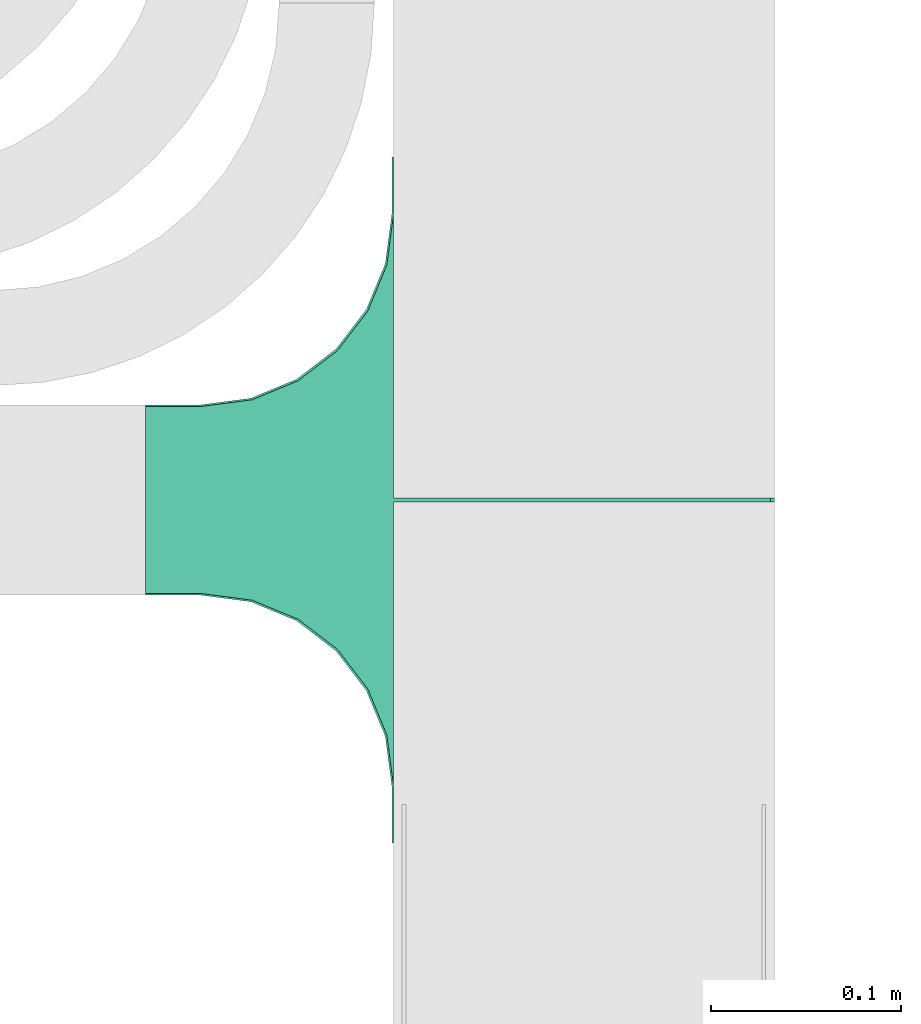
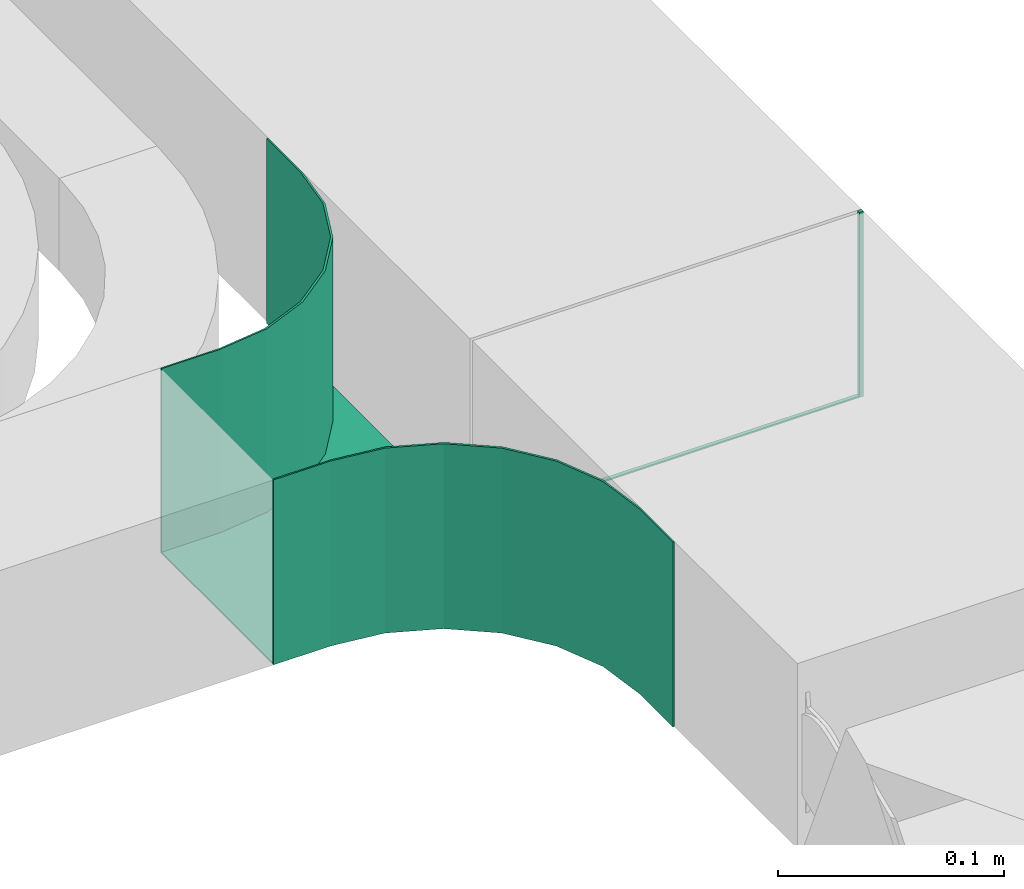
# One storey, part 23 of 23: 1 flow fitting.
"""IFC2X3 building model written with IfcOpenShell, lengths in millimetres."""

from ifc_helpers import new_model, entity, si_unit, converted_unit, derived_unit, direction, frame, origin, place, context, subcontext, project, spatial, faceted_brep, source, transform, mapped, material, type_object, type_shapes, element, save


model = new_model("IFC2X3")

# Units and contexts
model_context = context("Model", 3, precision=0.01, world=origin(), true_north=direction((6.12303176911189e-17, 1.0)))
body_context = subcontext(model_context, "Body", "Model", "MODEL_VIEW")
ifc_project = project(units=[si_unit("LENGTHUNIT", "METRE", prefix="MILLI"), si_unit("AREAUNIT", "SQUARE_METRE"), si_unit("VOLUMEUNIT", "CUBIC_METRE"), converted_unit("PLANEANGLEUNIT", "DEGREE", entity("IfcRatioMeasure", 0.0174532925199433), si_unit("PLANEANGLEUNIT", "RADIAN"), dimensions=[0, 0, 0, 0, 0, 0, 0]), si_unit("MASSUNIT", "GRAM", prefix="KILO"), derived_unit("MASSDENSITYUNIT", [(si_unit("MASSUNIT", "GRAM", prefix="KILO"), 1), (si_unit("LENGTHUNIT", "METRE"), -3)]), derived_unit("MOMENTOFINERTIAUNIT", [(si_unit("LENGTHUNIT", "METRE"), 4)]), si_unit("TIMEUNIT", "SECOND"), si_unit("FREQUENCYUNIT", "HERTZ"), si_unit("THERMODYNAMICTEMPERATUREUNIT", "DEGREE_CELSIUS"), derived_unit("THERMALTRANSMITTANCEUNIT", [(si_unit("MASSUNIT", "GRAM", prefix="KILO"), 1), (si_unit("THERMODYNAMICTEMPERATUREUNIT", "KELVIN"), -1), (si_unit("TIMEUNIT", "SECOND"), -3)]), derived_unit("VOLUMETRICFLOWRATEUNIT", [(si_unit("LENGTHUNIT", "METRE"), 3), (si_unit("TIMEUNIT", "SECOND"), -1)]), derived_unit("MASSFLOWRATEUNIT", [(si_unit("MASSUNIT", "GRAM", prefix="KILO"), 1), (si_unit("TIMEUNIT", "SECOND"), -1)]), derived_unit("ROTATIONALFREQUENCYUNIT", [(si_unit("TIMEUNIT", "SECOND"), -1)]), si_unit("ELECTRICCURRENTUNIT", "AMPERE"), si_unit("ELECTRICVOLTAGEUNIT", "VOLT"), si_unit("POWERUNIT", "WATT"), si_unit("FORCEUNIT", "NEWTON", prefix="KILO"), si_unit("ILLUMINANCEUNIT", "LUX"), si_unit("LUMINOUSFLUXUNIT", "LUMEN"), si_unit("LUMINOUSINTENSITYUNIT", "CANDELA"), derived_unit("USERDEFINED", [(si_unit("MASSUNIT", "GRAM", prefix="KILO"), -1), (si_unit("LENGTHUNIT", "METRE"), -2), (si_unit("TIMEUNIT", "SECOND"), 3), (si_unit("LUMINOUSFLUXUNIT", "LUMEN"), 1)]), derived_unit("LINEARVELOCITYUNIT", [(si_unit("LENGTHUNIT", "METRE"), 1), (si_unit("TIMEUNIT", "SECOND"), -1)]), si_unit("PRESSUREUNIT", "PASCAL"), derived_unit("USERDEFINED", [(si_unit("LENGTHUNIT", "METRE"), -2), (si_unit("MASSUNIT", "GRAM", prefix="KILO"), 1), (si_unit("TIMEUNIT", "SECOND"), -2)]), derived_unit("LINEARFORCEUNIT", [(si_unit("MASSUNIT", "GRAM", prefix="KILO"), 1), (si_unit("LENGTHUNIT", "METRE"), 1), (si_unit("TIMEUNIT", "SECOND"), -2), (si_unit("LENGTHUNIT", "METRE"), -1)]), derived_unit("PLANARFORCEUNIT", [(si_unit("MASSUNIT", "GRAM", prefix="KILO"), 1), (si_unit("LENGTHUNIT", "METRE"), 1), (si_unit("TIMEUNIT", "SECOND"), -2), (si_unit("LENGTHUNIT", "METRE"), -2)])], contexts=[model_context])

# Site, building, storey
site_placement = place(None, origin())
site = spatial("IfcSite", under=ifc_project, at=site_placement, CompositionType="ELEMENT")
building_placement = place(site_placement, origin())
building = spatial("IfcBuilding", under=site, at=building_placement, CompositionType="ELEMENT")
storey_placement = place(building_placement, frame((0.0, 0.0, 24000.0)))
storey = spatial("IfcBuildingStorey", under=building, at=storey_placement, CompositionType="ELEMENT", Elevation=24000.0)

# Flow fitting
ifc_material = material()
cable_carrier_fitting_type = type_object("IfcCableCarrierFittingType", PredefinedType="NOTDEFINED", material=ifc_material)
shared_shape = source(origin(), body_context, "Body", "Brep", [
    faceted_brep([(123.32, -103.41, 50.0), (99.2, -113.4, 50.0), (78.49, -129.29, 50.0), (62.6, -150.0, 50.0), (52.61, -174.12, 50.0), (49.2, -200.0, 50.0), (49.2, -230.0, 50.0), (50.0, -230.0, 50.0), (50.0, -200.8, 50.0), (53.41, -174.92, 50.0), (63.4, -150.8, 50.0), (79.29, -130.09, 50.0), (100.0, -114.2, 50.0), (124.12, -104.21, 50.0), (150.0, -100.8, 50.0), (180.0, -100.8, 50.0), (180.0, -100.0, 50.0), (149.2, -100.0, 50.0), (-149.2, -100.0, 50.0), (-180.0, -100.0, 50.0), (-180.0, -100.8, 50.0), (-150.0, -100.8, 50.0), (-124.12, -104.21, 50.0), (-100.0, -114.2, 50.0), (-79.29, -130.09, 50.0), (-63.4, -150.8, 50.0), (-53.41, -174.92, 50.0), (-50.0, -200.8, 50.0), (-50.0, -230.0, 50.0), (-49.2, -230.0, 50.0), (-49.2, -200.0, 50.0), (-52.61, -174.12, 50.0), (-62.6, -150.0, 50.0), (-78.49, -129.29, 50.0), (-99.2, -113.4, 50.0), (-123.32, -103.41, 50.0), (0.0, 100.0, 50.0), (-0.99, 100.0, 50.0), (-0.99, 98.0, 50.0), (0.99, 98.0, 50.0), (0.99, 100.0, 50.0), (-50.0, -200.8, -50.0), (-53.41, -174.92, -50.0), (-63.4, -150.8, -50.0), (-79.29, -130.09, -50.0), (-100.0, -114.2, -50.0), (-124.12, -104.21, -50.0), (-150.0, -100.8, -50.0), (-180.0, -100.8, -50.0), (-180.0, -100.0, -50.0), (-0.99, -100.0, -50.0), (-0.99, 100.0, -50.0), (0.0, 100.0, -50.0), (0.99, 100.0, -50.0), (0.99, -100.0, -50.0), (180.0, -100.0, -50.0), (180.0, -100.8, -50.0), (150.0, -100.8, -50.0), (124.12, -104.21, -50.0), (100.0, -114.2, -50.0), (79.29, -130.09, -50.0), (63.4, -150.8, -50.0), (53.41, -174.92, -50.0), (50.0, -200.8, -50.0), (50.0, -230.0, -50.0), (-50.0, -230.0, -50.0), (-50.0, -200.8, -49.2), (49.2, -230.0, -49.2), (-49.2, -230.0, -49.2), (-49.2, -200.0, -49.2), (-52.61, -174.12, -49.2), (-62.6, -150.0, -49.2), (-78.49, -129.29, -49.2), (-99.2, -113.4, -49.2), (-123.32, -103.41, -49.2), (-149.2, -100.0, -49.2), (-0.99, -100.0, -49.2), (0.99, -100.0, -49.2), (149.2, -100.0, -49.2), (-180.0, -100.8, -49.2), (-150.0, -100.8, -49.2), (150.0, -100.8, -49.2), (180.0, -100.8, -49.2), (50.0, -200.8, -49.2), (123.32, -103.41, -49.2), (99.2, -113.4, -49.2), (78.49, -129.29, -49.2), (62.6, -150.0, -49.2), (52.61, -174.12, -49.2), (49.2, -200.0, -49.2), (-0.99, 98.0, -49.2), (0.99, 98.0, -49.2), (0.0, 100.0, -49.2)], [[[0, 1, 2, 3, 4, 5, 6, 7, 8, 9, 10, 11, 12, 13, 14, 15, 16, 17]], [[18, 19, 20, 21, 22, 23, 24, 25, 26, 27, 28, 29, 30, 31, 32, 33, 34, 35]], [[36, 37, 38, 39, 40]], [[41, 42, 43, 44, 45, 46, 47, 48, 49, 50, 51, 52, 53, 54, 55, 56, 57, 58, 59, 60, 61, 62, 63, 64, 65]], [[28, 27, 66, 41, 65]], [[29, 28, 65, 64, 7, 6, 67, 68]], [[30, 29, 68, 69]], [[31, 70, 71, 32]], [[32, 71, 72, 33]], [[69, 70, 31, 30]], [[34, 73, 74, 35]], [[35, 74, 75, 18]], [[33, 72, 73, 34]], [[19, 18, 75, 76, 50, 49]], [[16, 55, 54, 77, 78, 17]], [[20, 19, 49, 48, 79]], [[21, 20, 79, 48, 47, 80]], [[15, 14, 81, 57, 56, 82]], [[22, 21, 80, 47, 46]], [[23, 22, 46, 45]], [[45, 44, 24, 23]], [[25, 24, 44, 43]], [[26, 25, 43, 42]], [[27, 26, 42, 41, 66]], [[9, 8, 83, 63, 62]], [[10, 9, 62, 61]], [[11, 10, 61, 60]], [[13, 12, 59, 58]], [[13, 58, 57, 81, 14]], [[59, 12, 11, 60]], [[16, 15, 82, 56, 55]], [[0, 84, 85, 1]], [[1, 85, 86, 2]], [[78, 84, 0, 17]], [[3, 87, 88, 4]], [[4, 88, 89, 5]], [[2, 86, 87, 3]], [[6, 5, 89, 67]], [[8, 7, 64, 63, 83]], [[90, 76, 75, 74, 73, 72, 71, 70, 69, 68, 67, 89, 88, 87, 86, 85, 84, 78, 77, 91]], [[37, 51, 50, 76, 90, 38]], [[39, 38, 90, 91]], [[40, 39, 91, 77, 54, 53]], [[36, 40, 92]], [[37, 36, 92]], [[53, 92, 40]], [[92, 53, 52]], [[92, 52, 51]], [[92, 51, 37]]]),
])
type_shapes(cable_carrier_fitting_type, [shared_shape])
flow_fitting_placement = place(storey_placement, frame((17813.15, 11559.43, 3390.0), z_axis=(0.0, 0.0, 1.0), x_axis=(0.0, -1.0, 0.0)))
element("IfcFlowFitting", 1, at=flow_fitting_placement, inside=storey, type_object=cable_carrier_fitting_type, material=ifc_material, context=body_context, shape_type="MappedRepresentation", body=[
    mapped(shared_shape, transform((0.0, 0.0, 0.0), scale=1.0)),
])

save(model, "model.ifc")
